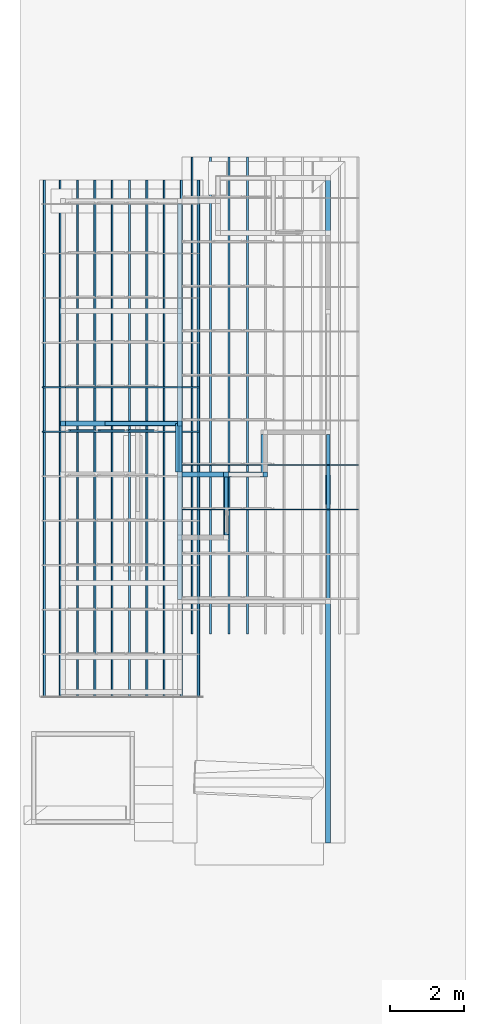
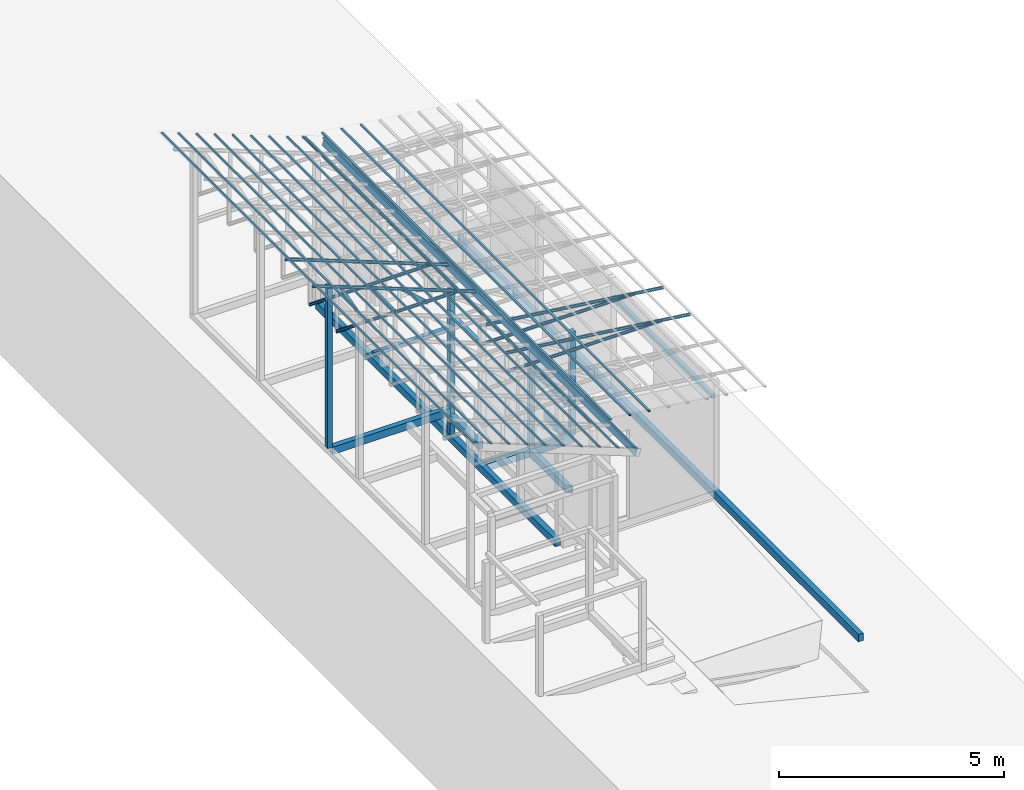
# One storey, part 9 of 22: 26 members, 15 beams, 2 elements without a shape of their own.
"""IFC4 building model written with IfcOpenShell, lengths in millimetres."""

from ifc_helpers import new_model, entity, si_unit, converted_unit, frame, origin_with_axes, origin_2d_with_axis, place, context, subcontext, project, spatial, indexed_curve, rectangle, hollow_rectangle, c_section, outline, extrude, clip, halfspace, material, material_profile, profile_set, profile_usage, type_object, element, aggregate, save


model = new_model("IFC4")

# Units and contexts
model_context = context("Model", 3, precision=1e-05, world=origin_with_axes())
plan_context = context("Plan", 2, precision=1e-05, world=origin_2d_with_axis())
body_context = subcontext(model_context, "Body", "Model", "MODEL_VIEW")
ifc_project = project(units=[si_unit("VOLUMEUNIT", "CUBIC_METRE"), si_unit("LENGTHUNIT", "METRE", prefix="MILLI"), si_unit("AREAUNIT", "SQUARE_METRE"), converted_unit("PLANEANGLEUNIT", "degree", entity("IfcReal", 0.0174532925199433), si_unit("PLANEANGLEUNIT", "RADIAN"), dimensions=[0, 0, 0, 0, 0, 0, 0])], contexts=[model_context, plan_context])

# Site, building, storey
site_placement = place(None, origin_with_axes())
site = spatial("IfcSite", under=ifc_project, at=site_placement)
building_placement = place(site_placement, origin_with_axes())
building = spatial("IfcBuilding", under=site, at=building_placement, Name="2")
storey_placement = place(building_placement, frame((0.0, 0.0, 200.000002980232), z_axis=(0.0, 0.0, 1.0), x_axis=(1.0, 0.0, 0.0)))
storey = spatial("IfcBuildingStorey", under=building, at=storey_placement)

# Beams
ifc_material_1 = material(Name="Concrete")
ifc_material_profile_1 = material_profile(ifc_material_1, outline(indexed_curve([(-65.0, 99.9999923706055), (65.0, 99.9999923706055), (65.0, -99.9999923706055), (-65.0, -99.9999923706055), (-65.0, 99.9999923706055)])))
ifc_profile_set_1 = profile_set([ifc_material_profile_1])
ifc_profile_usage_1 = profile_usage(ifc_profile_set_1, cardinal=2)
beam_type_1 = type_object("IfcBeamType", PredefinedType="BEAM", material=ifc_profile_set_1)
beam_1_placement = place(storey_placement, frame((0.0, 0.0, -200.000002980232), z_axis=(1.50995802528082e-07, 0.99999999999997, 1.94707183709391e-07), x_axis=(-0.999999999999989, 1.50995798738838e-07, 3.24144179769981e-11)))
element("IfcBeam", 1, at=beam_1_placement, inside=storey, type_object=beam_type_1, material=ifc_profile_usage_1, Name="Beam", PredefinedType="BEAM", context=body_context, shape_type="Clipping", body=[
    clip(extrude(outline(indexed_curve([(-65.0, 99.9999923706055), (65.0, 99.9999923706055), (65.0, -99.9999923706055), (-65.0, -99.9999923706055), (-65.0, 99.9999923706055)])), frame((0.0, 100.0, 0.0), z_axis=(0.0, 0.0, 1.0), x_axis=(1.0, 0.0, 0.0)), (0.0, 0.0, 1.0), 17980.0015723856), halfspace(frame((-65.0000050663948, -0.00457252690466703, 17980.001449585), z_axis=(0.707109749317169, -1.79824851898047e-07, 0.707103788852692), x_axis=(-2.54309676923125e-07, -0.999999999999968, 0.0)), False)),
])
ifc_profile_usage_2 = profile_usage(ifc_profile_set_1, cardinal=2)
beam_2_placement = place(storey_placement, frame((-2749.99499320984, 8165.00186920166, -200.000161831838), z_axis=(8.74227978897559e-08, 0.999999999999977, 1.94707183709393e-07), x_axis=(-0.999999999999992, 8.74227765734752e-08, 8.74227836789026e-08)))
element("IfcBeam", 2, at=beam_2_placement, inside=storey, type_object=beam_type_1, material=ifc_profile_usage_2, Name="Beam", PredefinedType="BEAM", context=body_context, shape_type="Clipping", body=[
    clip(extrude(outline(indexed_curve([(-65.0, 99.9999923706055), (65.0, 99.9999923706055), (65.0, -99.9999923706055), (-65.0, -99.9999923706055), (-65.0, 99.9999923706055)])), frame((0.0, 100.0, 0.0), z_axis=(0.0, 0.0, 1.0), x_axis=(1.0, 0.0, 0.0)), (0.0, 0.0, 1.0), 1699.99883876093), halfspace(frame((-65.000057220459, 0.000885935833139229, -0.00118840398499742), z_axis=(0.70710414648056, 9.55323073981162e-08, -0.707109451293945), x_axis=(1.35103588168171e-07, -0.999999999999991, 0.0)), False)),
])
ifc_profile_usage_3 = profile_usage(ifc_profile_set_1, cardinal=2)
beam_3_placement = place(storey_placement, frame((-3934.99755859375, 9930.00030517578, -199.999908873252), z_axis=(0.999999999999825, 5.20548553595199e-07, -2.82129974493678e-07), x_axis=(-5.2054855359522e-07, 0.999999999999865, 5.68434188608003e-14)))
element("IfcBeam", 3, at=beam_3_placement, inside=storey, type_object=beam_type_1, material=ifc_profile_usage_3, Name="Beam", PredefinedType="BEAM", context=body_context, shape_type="Clipping", body=[
    clip(extrude(outline(indexed_curve([(-65.0, 99.9999923706055), (65.0, 99.9999923706055), (65.0, -99.9999923706055), (-65.0, -99.9999923706055), (-65.0, 99.9999923706055)])), frame((0.0, 100.0, 0.0), z_axis=(0.0, 0.0, 1.0), x_axis=(1.0, 0.0, 0.0)), (0.0, 0.0, 1.0), 2254.99774281488), halfspace(frame((-64.9996623396873, 0.000666959067530115, 2254.99749183655), z_axis=(0.707109272480011, 1.46940550393992e-07, 0.707104206085205), x_axis=(2.07804587088261e-07, -0.999999999999978, 0.0)), False)),
])
ifc_profile_usage_4 = profile_usage(ifc_profile_set_1, cardinal=2)
beam_4_placement = place(storey_placement, frame((-1745.00000476837, 9865.0016784668, -200.000298664889), z_axis=(-3.89414367418764e-07, 0.999999999999921, 7.54979012640374e-08), x_axis=(-0.999999999999921, -3.89414367418764e-07, 7.43238217637496e-08)))
element("IfcBeam", 4, at=beam_4_placement, inside=storey, type_object=beam_type_1, material=ifc_profile_usage_4, Name="Beam", PredefinedType="BEAM", context=body_context, shape_type="Clipping", body=[
    clip(extrude(outline(indexed_curve([(-65.0, 99.9999923706055), (65.0, 99.9999923706055), (65.0, -99.9999923706055), (-65.0, -99.9999923706055), (-65.0, 99.9999923706055)])), frame((0.0, 100.0, 0.0), z_axis=(0.0, 0.0, 1.0), x_axis=(1.0, 0.0, 0.0)), (0.0, 0.0, 1.0), 1135.00023417544), halfspace(frame((-65.0000870227814, 0.000425379340640575, -0.000299458179142675), z_axis=(0.70710414648056, 5.33852926309919e-08, -0.707109332084656), x_axis=(7.54984861801534e-08, -0.999999999999997, 0.0)), False)),
])
ifc_profile_usage_5 = profile_usage(ifc_profile_set_1, cardinal=3)
beam_5_placement = place(storey_placement, frame((-3934.99732017517, 6565.00053405762, -200.00042633302), z_axis=(3.89414367418746e-07, 0.999999999999875, 3.13916473260139e-07), x_axis=(-0.999999999999924, 3.89414367418765e-07, -7.40532613008271e-09)))
element("IfcBeam", 5, at=beam_5_placement, inside=storey, type_object=beam_type_1, material=ifc_profile_usage_5, Name="Beam", PredefinedType="BEAM", context=body_context, shape_type="SweptSolid", body=[
    extrude(outline(indexed_curve([(-65.0, 99.9999923706055), (65.0, 99.9999923706055), (65.0, -99.9999923706055), (-65.0, -99.9999923706055), (-65.0, 99.9999923706055)])), frame((65.0000076293945, 100.0, 0.0), z_axis=(0.0, 0.0, 1.0), x_axis=(1.0, 0.0, 0.0)), (0.0, 0.0, 1.0), 10669.999992565),
])
ifc_profile_usage_6 = profile_usage(ifc_profile_set_1, cardinal=2)
beam_6_placement = place(storey_placement, frame((-7084.99765396118, 11300.0049591064, 535.000070929528), z_axis=(0.999999999999932, -1.9470714107682e-07, 3.13916473260157e-07), x_axis=(1.94707183709391e-07, 0.99999999999997, -1.49011611938472e-07)))
element("IfcBeam", 6, at=beam_6_placement, inside=storey, type_object=beam_type_1, material=ifc_profile_usage_6, Name="Beam", PredefinedType="BEAM", context=body_context, shape_type="SweptSolid", body=[
    extrude(outline(indexed_curve([(-65.0, 99.9999923706055), (65.0, 99.9999923706055), (65.0, -99.9999923706055), (-65.0, -99.9999923706055), (-65.0, 99.9999923706055)])), frame((0.0, 100.0, 0.0), z_axis=(0.0, 0.0, 1.0), x_axis=(1.0, 0.0, 0.0)), (0.0, 0.0, 1.0), 3020.00196570558),
])
ifc_profile_usage_7 = profile_usage(ifc_profile_set_1, cardinal=3)
beam_7_placement = place(storey_placement, frame((-3934.99612808228, 9994.99988555908, 355.003580451012), z_axis=(3.89414367418746e-07, 0.999999999999875, 3.13916473260139e-07), x_axis=(-0.999999999999924, 3.89414367418765e-07, -7.40532613008271e-09)))
element("IfcBeam", 7, at=beam_7_placement, inside=storey, type_object=beam_type_1, material=ifc_profile_usage_7, Name="Beam", PredefinedType="BEAM", context=body_context, shape_type="SweptSolid", body=[
    extrude(outline(indexed_curve([(-65.0, 99.9999923706055), (65.0, 99.9999923706055), (65.0, -99.9999923706055), (-65.0, -99.9999923706055), (-65.0, 99.9999923706055)])), frame((65.0000076293945, 100.0, 0.0), z_axis=(0.0, 0.0, 1.0), x_axis=(1.0, 0.0, 0.0)), (0.0, 0.0, 1.0), 1365.22865567095),
])
ifc_material_profile_2 = material_profile(ifc_material_1, rectangle(XDim=130.000015258789, YDim=130.000015258789, kind="CURVE"))
ifc_profile_set_2 = profile_set([ifc_material_profile_2])
ifc_profile_usage_8 = profile_usage(ifc_profile_set_2, cardinal=5)
beam_type_2 = type_object("IfcBeamType", PredefinedType="BEAM", material=ifc_profile_set_2)
beam_8_placement = place(storey_placement, frame((-3999.99690055847, 11305.5725097656, -1.49011609718031e-05), z_axis=(0.0, 0.0, 1.0), x_axis=(1.0, 0.0, 0.0)))
element("IfcBeam", 8, at=beam_8_placement, inside=storey, type_object=beam_type_2, material=ifc_profile_usage_8, Name="Column", PredefinedType="BEAM", context=body_context, shape_type="SweptSolid", body=[
    extrude(rectangle(XDim=130.000015258789, YDim=130.000015258789, kind="CURVE"), origin_with_axes(), (0.0, 0.0, 1.0), 3934.94913943236),
])
ifc_profile_usage_9 = profile_usage(ifc_profile_set_2, cardinal=5)
beam_9_placement = place(storey_placement, frame((-7149.99771118164, 11300.0059127808, 735.000059008599), z_axis=(0.0, 0.0, 1.0), x_axis=(1.0, 0.0, 0.0)))
element("IfcBeam", 9, at=beam_9_placement, inside=storey, type_object=beam_type_2, material=ifc_profile_usage_9, Name="Column", PredefinedType="BEAM", context=body_context, shape_type="SweptSolid", body=[
    extrude(rectangle(XDim=130.000015258789, YDim=130.000015258789, kind="CURVE"), origin_with_axes(), (0.0, 0.0, 1.0), 4411.20902133499),
])
ifc_profile_usage_10 = profile_usage(ifc_profile_set_2, cardinal=5)
beam_10_placement = place(storey_placement, frame((-2749.99475479126, 9929.99935150146, -0.000312924384848756), z_axis=(0.0, 0.0, 1.0), x_axis=(1.0, 0.0, 0.0)))
element("IfcBeam", 10, at=beam_10_placement, inside=storey, type_object=beam_type_2, material=ifc_profile_usage_10, Name="Column", PredefinedType="BEAM", context=body_context, shape_type="SweptSolid", body=[
    extrude(rectangle(XDim=130.000015258789, YDim=130.000015258789, kind="CURVE"), origin_with_axes(), (0.0, 0.0, 1.0), 2811.24256423096),
])
ifc_profile_usage_11 = profile_usage(ifc_profile_set_2, cardinal=5)
beam_11_placement = place(storey_placement, frame((-1695.00029087067, 9930.15480041504, -0.000610947608725709), z_axis=(0.0, 0.0, 1.0), x_axis=(1.0, 0.0, 0.0)))
element("IfcBeam", 11, at=beam_11_placement, inside=storey, type_object=beam_type_2, material=ifc_profile_usage_11, Name="Column", PredefinedType="BEAM", context=body_context, shape_type="SweptSolid", body=[
    extrude(rectangle(XDim=130.000015258789, YDim=130.000015258789, kind="CURVE"), origin_with_axes(), (0.0, 0.0, 1.0), 2811.24349712944),
])

# Assembly, members
assembly_1_placement = place(storey_placement, frame((-1561.45393848419, 6600.0657081604, 3019.63977515697), z_axis=(0.0, 0.0, 1.0), x_axis=(1.0, 0.0, 0.0)))
assembly_1 = element("IfcElementAssembly", 12, at=assembly_1_placement, inside=storey, Name="K1")
ifc_material_2 = material(Name="STEEL")
ifc_material_profile_3 = material_profile(ifc_material_2, c_section(Depth=75.0, Width=35.0, WallThickness=1.0, Girth=1.0, kind="CURVE"))
ifc_profile_set_3 = profile_set([ifc_material_profile_3])
ifc_profile_usage_12 = profile_usage(ifc_profile_set_3, cardinal=9)
member_type_1 = type_object("IfcMemberType", Name="C75", PredefinedType="CHORD", material=ifc_profile_set_3)
member_1_placement = place(assembly_1_placement, frame((2381.98524713516, 2398.93293380737, -28.5120010375977), z_axis=(-0.991864132670109, -9.11591360127481e-08, 0.127300991050989), x_axis=(7.54979012640425e-08, -0.999999999999989, -1.2785038450147e-07)))
member_1 = element("IfcMember", 13, at=member_1_placement, type_object=member_type_1, material=ifc_profile_usage_12, Name="Member", context=body_context, shape_type="SweptSolid", body=[
    extrude(c_section(Depth=75.0, Width=35.0, WallThickness=1.0, Girth=1.0, kind="CURVE"), frame((17.5, -37.5, 0.0), z_axis=(0.0, 0.0, 1.0), x_axis=(1.0, 0.0, 0.0)), (0.0, 0.0, 1.0), 4790.46084290085),
])
ifc_profile_usage_13 = profile_usage(ifc_profile_set_3, cardinal=9)
member_2_placement = place(assembly_1_placement, frame((1634.4433426857, 2398.93293380737, 64.9838447570801), z_axis=(-0.999999999999996, -7.54978941586157e-08, -4.37113882867378e-08), x_axis=(7.54979012640425e-08, -0.999999999999989, -1.2785038450147e-07)))
member_2 = element("IfcMember", 14, at=member_2_placement, type_object=member_type_1, material=ifc_profile_usage_13, Name="Member", context=body_context, shape_type="SweptSolid", body=[
    extrude(c_section(Depth=75.0, Width=35.0, WallThickness=1.0, Girth=1.0, kind="CURVE"), frame((17.5, -37.5, 0.0), z_axis=(0.0, 0.0, 1.0), x_axis=(1.0, 0.0, 0.0)), (0.0, 0.0, 1.0), 4007.95455591631),
])
ifc_profile_usage_14 = profile_usage(ifc_profile_set_3, cardinal=9)
member_3_placement = place(assembly_1_placement, frame((1634.4433426857, 3598.93274307251, 64.9838447570801), z_axis=(-0.999999999999996, -7.54978941586157e-08, -4.37113882867378e-08), x_axis=(7.54979012640425e-08, -0.999999999999989, -1.2785038450147e-07)))
member_3 = element("IfcMember", 15, at=member_3_placement, type_object=member_type_1, material=ifc_profile_usage_14, Name="Member", context=body_context, shape_type="SweptSolid", body=[
    extrude(c_section(Depth=75.0, Width=35.0, WallThickness=1.0, Girth=1.0, kind="CURVE"), frame((17.5, -37.5, 0.0), z_axis=(0.0, 0.0, 1.0), x_axis=(1.0, 0.0, 0.0)), (0.0, 0.0, 1.0), 4007.95455591631),
])
ifc_profile_usage_15 = profile_usage(ifc_profile_set_3, cardinal=9)
member_4_placement = place(assembly_1_placement, frame((2381.98524713516, 3598.93274307251, -28.5120010375977), z_axis=(-0.991864132670109, -9.11591360127481e-08, 0.127300991050989), x_axis=(7.54979012640425e-08, -0.999999999999989, -1.2785038450147e-07)))
member_4 = element("IfcMember", 16, at=member_4_placement, type_object=member_type_1, material=ifc_profile_usage_15, Name="Member", context=body_context, shape_type="SweptSolid", body=[
    extrude(c_section(Depth=75.0, Width=35.0, WallThickness=1.0, Girth=1.0, kind="CURVE"), frame((17.5, -37.5, 0.0), z_axis=(0.0, 0.0, 1.0), x_axis=(1.0, 0.0, 0.0)), (0.0, 0.0, 1.0), 4790.46084290085),
])
aggregate(assembly_1, [member_1, member_2, member_3, member_4])

assembly_2_placement = place(storey_placement, frame((-3938.51041793823, 5099.00283813477, 3935.3459328413), z_axis=(0.0, 0.0, 1.0), x_axis=(1.0, 0.0, 0.0)))
assembly_2 = element("IfcElementAssembly", 17, at=assembly_2_placement, inside=storey, Name="2")
ifc_profile_usage_16 = profile_usage(ifc_profile_set_3, cardinal=1)
member_5_placement = place(assembly_2_placement, frame((3.51285934448242, 5964.99919891357, -1.35517120361328), z_axis=(-0.999999999999812, -4.33125762810878e-07, 4.33125762810878e-07), x_axis=(4.33125762810919e-07, -0.999999999999906, -1.13742348872837e-13)))
member_5 = element("IfcMember", 18, at=member_5_placement, type_object=member_type_1, material=ifc_profile_usage_16, Name="Member", context=body_context, shape_type="SweptSolid", body=[
    extrude(c_section(Depth=75.0, Width=35.0, WallThickness=1.0, Girth=1.0, kind="CURVE"), frame((-17.5, 37.5, 0.0), z_axis=(0.0, 0.0, 1.0), x_axis=(1.0, 0.0, 0.0)), (0.0, 0.0, 1.0), 3150.02386296032),
])
ifc_profile_usage_17 = profile_usage(ifc_profile_set_3, cardinal=3)
member_6_placement = place(assembly_2_placement, frame((-2271.51107788086, 5999.99904632568, 894.618034362793), z_axis=(0.578723368640778, -7.49756619914683e-07, -0.815523919078103), x_axis=(1.02917226740772e-06, 0.999999999999453, -1.89020340712783e-07)))
member_6 = element("IfcMember", 19, at=member_6_placement, type_object=member_type_1, material=ifc_profile_usage_17, Name="Member", context=body_context, shape_type="SweptSolid", body=[
    extrude(c_section(Depth=75.0, Width=35.0, WallThickness=1.0, Girth=1.0, kind="CURVE"), frame((17.5, 37.5, 0.0), z_axis=(0.0, 0.0, 1.0), x_axis=(1.0, 0.0, 0.0)), (0.0, 0.0, 1.0), 1142.30360336039),
])
ifc_profile_usage_18 = profile_usage(ifc_profile_set_3, cardinal=7)
member_7_placement = place(assembly_2_placement, frame((-1445.26290893555, 6035.96019744873, 624.074935913086), z_axis=(0.745142107017777, -0.00102660805644996, -0.66690493057482), x_axis=(0.00137753843534741, 0.999999051193456, -2.17762747561669e-07)))
member_7 = element("IfcMember", 20, at=member_7_placement, type_object=member_type_1, material=ifc_profile_usage_18, Name="Member", context=body_context, shape_type="SweptSolid", body=[
    extrude(c_section(Depth=75.0, Width=35.0, WallThickness=1.0, Girth=1.0, kind="CURVE"), frame((-17.5, -37.5, 0.0), z_axis=(0.0, 0.0, 1.0), x_axis=(1.0, 0.0, 0.0)), (0.0, 0.0, 1.0), 937.808496265298),
])
ifc_profile_usage_19 = profile_usage(ifc_profile_set_3, cardinal=9)
member_8_placement = place(assembly_2_placement, frame((-3006.42156600952, 5999.99809265137, 1241.45650863647), z_axis=(0.468464370953309, -3.43728484817469e-07, -0.88348238983423), x_axis=(6.7154434191237e-07, 0.999999999999774, -3.29761675743537e-08)))
member_8 = element("IfcMember", 21, at=member_8_placement, type_object=member_type_1, material=ifc_profile_usage_19, Name="Member", context=body_context, shape_type="SweptSolid", body=[
    extrude(c_section(Depth=75.0, Width=35.0, WallThickness=1.0, Girth=1.0, kind="CURVE"), frame((17.5, -37.5, 0.0), z_axis=(0.0, 0.0, 1.0), x_axis=(1.0, 0.0, 0.0)), (0.0, 0.0, 1.0), 1399.63894386164),
])
ifc_profile_usage_20 = profile_usage(ifc_profile_set_3, cardinal=1)
member_9_placement = place(assembly_2_placement, frame((438.234329223633, 5965.00015258789, -169.034004211426), z_axis=(-0.933001152035968, -8.32115964913738e-07, 0.359873380925658), x_axis=(9.09962921013707e-07, -0.999999999999585, 4.6906695416718e-08)))
member_9 = element("IfcMember", 22, at=member_9_placement, type_object=member_type_1, material=ifc_profile_usage_20, Name="Member", context=body_context, shape_type="SweptSolid", body=[
    extrude(c_section(Depth=75.0, Width=35.0, WallThickness=1.0, Girth=1.0, kind="CURVE"), frame((-17.5, 37.5, 0.0), z_axis=(0.0, 0.0, 1.0), x_axis=(1.0, 0.0, 0.0)), (0.0, 0.0, 1.0), 4510.0754953159),
])
ifc_profile_usage_21 = profile_usage(ifc_profile_set_3, cardinal=1)
member_10_placement = place(assembly_2_placement, frame((3.51285934448242, 7164.99900817871, -1.35517120361328), z_axis=(-0.999999999999812, -4.33125762810878e-07, 4.33125762810878e-07), x_axis=(4.33125762810919e-07, -0.999999999999906, -1.13742348872837e-13)))
member_10 = element("IfcMember", 23, at=member_10_placement, type_object=member_type_1, material=ifc_profile_usage_21, Name="Member", context=body_context, shape_type="SweptSolid", body=[
    extrude(c_section(Depth=75.0, Width=35.0, WallThickness=1.0, Girth=1.0, kind="CURVE"), frame((-17.5, 37.5, 0.0), z_axis=(0.0, 0.0, 1.0), x_axis=(1.0, 0.0, 0.0)), (0.0, 0.0, 1.0), 3150.02386296032),
])
ifc_profile_usage_22 = profile_usage(ifc_profile_set_3, cardinal=1)
member_11_placement = place(assembly_2_placement, frame((438.234329223633, 7164.99996185303, -169.034004211426), z_axis=(-0.933001152035968, -8.32115964913738e-07, 0.359873380925658), x_axis=(9.09962921013707e-07, -0.999999999999585, 4.6906695416718e-08)))
member_11 = element("IfcMember", 24, at=member_11_placement, type_object=member_type_1, material=ifc_profile_usage_22, Name="Member", context=body_context, shape_type="SweptSolid", body=[
    extrude(c_section(Depth=75.0, Width=35.0, WallThickness=1.0, Girth=1.0, kind="CURVE"), frame((-17.5, 37.5, 0.0), z_axis=(0.0, 0.0, 1.0), x_axis=(1.0, 0.0, 0.0)), (0.0, 0.0, 1.0), 4510.0754953159),
])
aggregate(assembly_2, [member_5, member_6, member_7, member_8, member_9, member_10, member_11])

# Members
ifc_material_profile_4 = material_profile(ifc_material_2, hollow_rectangle(XDim=50.0, YDim=33.0, WallThickness=1.0, InnerFilletRadius=1.0, OuterFilletRadius=0.0, kind="CURVE"))
ifc_profile_set_4 = profile_set([ifc_material_profile_4])
ifc_profile_usage_23 = profile_usage(ifc_profile_set_4, cardinal=3)
member_type_2 = type_object("IfcMemberType", PredefinedType="CHORD", material=ifc_profile_set_4)
member_12_placement = place(storey_placement, frame((-2155.15184402466, 5634.99975204468, 3372.32188880444), z_axis=(5.55417489778164e-09, 0.999999999999999, 4.33570832569785e-08), x_axis=(-0.99189443015292, 0.0, 0.127064705688141)))
element("IfcMember", 25, at=member_12_placement, inside=storey, type_object=member_type_2, material=ifc_profile_usage_23, Name="Member", context=body_context, shape_type="SweptSolid", body=[
    extrude(hollow_rectangle(XDim=50.0, YDim=33.0, WallThickness=1.0, InnerFilletRadius=1.0, OuterFilletRadius=0.0, kind="CURVE"), frame((25.0, 16.5, 0.0), z_axis=(0.0, 0.0, 1.0), x_axis=(1.0, 0.0, 0.0)), (0.0, 0.0, 1.0), 12845.0009370286),
])
ifc_profile_usage_24 = profile_usage(ifc_profile_set_4, cardinal=3)
member_13_placement = place(storey_placement, frame((-2651.09920501709, 5634.99975204468, 3435.85424125195), z_axis=(5.55417489778164e-09, 0.999999999999999, 4.33570832569785e-08), x_axis=(-0.99189443015292, 0.0, 0.127064705688141)))
element("IfcMember", 26, at=member_13_placement, inside=storey, type_object=member_type_2, material=ifc_profile_usage_24, Name="Member", context=body_context, shape_type="SweptSolid", body=[
    extrude(hollow_rectangle(XDim=50.0, YDim=33.0, WallThickness=1.0, InnerFilletRadius=1.0, OuterFilletRadius=0.0, kind="CURVE"), frame((25.0, 16.5, 0.0), z_axis=(0.0, 0.0, 1.0), x_axis=(1.0, 0.0, 0.0)), (0.0, 0.0, 1.0), 12845.0009370286),
])
ifc_profile_usage_25 = profile_usage(ifc_profile_set_4, cardinal=3)
member_14_placement = place(storey_placement, frame((-3147.04632759094, 5634.99975204468, 3499.38659369946), z_axis=(5.55417489778164e-09, 0.999999999999999, 4.33570832569785e-08), x_axis=(-0.99189443015292, 0.0, 0.127064705688141)))
element("IfcMember", 27, at=member_14_placement, inside=storey, type_object=member_type_2, material=ifc_profile_usage_25, Name="Member", context=body_context, shape_type="SweptSolid", body=[
    extrude(hollow_rectangle(XDim=50.0, YDim=33.0, WallThickness=1.0, InnerFilletRadius=1.0, OuterFilletRadius=0.0, kind="CURVE"), frame((25.0, 16.5, 0.0), z_axis=(0.0, 0.0, 1.0), x_axis=(1.0, 0.0, 0.0)), (0.0, 0.0, 1.0), 12845.0009370286),
])
ifc_profile_usage_26 = profile_usage(ifc_profile_set_4, cardinal=3)
member_15_placement = place(storey_placement, frame((-3642.99345016479, 5634.99975204468, 3562.91894614697), z_axis=(5.55417489778164e-09, 0.999999999999999, 4.33570832569785e-08), x_axis=(-0.99189443015292, 0.0, 0.127064705688141)))
element("IfcMember", 28, at=member_15_placement, inside=storey, type_object=member_type_2, material=ifc_profile_usage_26, Name="Member", context=body_context, shape_type="SweptSolid", body=[
    extrude(hollow_rectangle(XDim=50.0, YDim=33.0, WallThickness=1.0, InnerFilletRadius=1.0, OuterFilletRadius=0.0, kind="CURVE"), frame((25.0, 16.5, 0.0), z_axis=(0.0, 0.0, 1.0), x_axis=(1.0, 0.0, 0.0)), (0.0, 0.0, 1.0), 12845.0009370286),
])
ifc_profile_usage_27 = profile_usage(ifc_profile_set_4, cardinal=3)
member_16_placement = place(storey_placement, frame((-3473.28567504883, 3935.00542640686, 3836.28682792187), z_axis=(-6.02437779662066e-08, 0.999999999999996, 7.04360303416249e-08), x_axis=(-0.932953539230607, -8.15613889917279e-08, 0.359996796703911)))
element("IfcMember", 29, at=member_16_placement, inside=storey, type_object=member_type_2, material=ifc_profile_usage_27, Name="Member", context=body_context, shape_type="SweptSolid", body=[
    extrude(hollow_rectangle(XDim=50.0, YDim=33.0, WallThickness=1.0, InnerFilletRadius=1.0, OuterFilletRadius=0.0, kind="CURVE"), frame((25.0, 16.5, 0.0), z_axis=(0.0, 0.0, 1.0), x_axis=(1.0, 0.0, 0.0)), (0.0, 0.0, 1.0), 13930.0024282614),
])
ifc_profile_usage_28 = profile_usage(ifc_profile_set_4, cardinal=3)
member_17_placement = place(storey_placement, frame((-3939.76235389709, 3935.00542640686, 4016.28522574902), z_axis=(-6.74248781251661e-08, 0.999999999999997, 4.07806979296764e-08), x_axis=(-0.932953576983475, -7.75851971190367e-08, 0.359996698865048)))
element("IfcMember", 30, at=member_17_placement, inside=storey, type_object=member_type_2, material=ifc_profile_usage_28, Name="Member", context=body_context, shape_type="SweptSolid", body=[
    extrude(hollow_rectangle(XDim=50.0, YDim=33.0, WallThickness=1.0, InnerFilletRadius=1.0, OuterFilletRadius=0.0, kind="CURVE"), frame((25.0, 16.5, 0.0), z_axis=(0.0, 0.0, 1.0), x_axis=(1.0, 0.0, 0.0)), (0.0, 0.0, 1.0), 13930.0024282614),
])
ifc_profile_usage_29 = profile_usage(ifc_profile_set_4, cardinal=3)
member_18_placement = place(storey_placement, frame((-4406.23903274536, 3935.00518798828, 4196.28362357616), z_axis=(-6.74248781251661e-08, 0.999999999999997, 4.07806979296764e-08), x_axis=(-0.932953576983475, -7.75851971190367e-08, 0.359996698865048)))
element("IfcMember", 31, at=member_18_placement, inside=storey, type_object=member_type_2, material=ifc_profile_usage_29, Name="Member", context=body_context, shape_type="SweptSolid", body=[
    extrude(hollow_rectangle(XDim=50.0, YDim=33.0, WallThickness=1.0, InnerFilletRadius=1.0, OuterFilletRadius=0.0, kind="CURVE"), frame((25.0, 16.5, 0.0), z_axis=(0.0, 0.0, 1.0), x_axis=(1.0, 0.0, 0.0)), (0.0, 0.0, 1.0), 13930.0024282614),
])
ifc_profile_usage_30 = profile_usage(ifc_profile_set_4, cardinal=3)
member_19_placement = place(storey_placement, frame((-4872.71595001221, 3935.00518798828, 4376.28202140331), z_axis=(-6.74248781251661e-08, 0.999999999999997, 4.07806979296764e-08), x_axis=(-0.932953576983475, -7.75851971190367e-08, 0.359996698865048)))
element("IfcMember", 32, at=member_19_placement, inside=storey, type_object=member_type_2, material=ifc_profile_usage_30, Name="Member", context=body_context, shape_type="SweptSolid", body=[
    extrude(hollow_rectangle(XDim=50.0, YDim=33.0, WallThickness=1.0, InnerFilletRadius=1.0, OuterFilletRadius=0.0, kind="CURVE"), frame((25.0, 16.5, 0.0), z_axis=(0.0, 0.0, 1.0), x_axis=(1.0, 0.0, 0.0)), (0.0, 0.0, 1.0), 13930.0024282614),
])
ifc_profile_usage_31 = profile_usage(ifc_profile_set_4, cardinal=3)
member_20_placement = place(storey_placement, frame((-5339.19286727905, 3935.00518798828, 4556.28041923046), z_axis=(-6.74248781251661e-08, 0.999999999999997, 4.07806979296764e-08), x_axis=(-0.932953576983475, -7.75851971190367e-08, 0.359996698865048)))
element("IfcMember", 33, at=member_20_placement, inside=storey, type_object=member_type_2, material=ifc_profile_usage_31, Name="Member", context=body_context, shape_type="SweptSolid", body=[
    extrude(hollow_rectangle(XDim=50.0, YDim=33.0, WallThickness=1.0, InnerFilletRadius=1.0, OuterFilletRadius=0.0, kind="CURVE"), frame((25.0, 16.5, 0.0), z_axis=(0.0, 0.0, 1.0), x_axis=(1.0, 0.0, 0.0)), (0.0, 0.0, 1.0), 13930.0024282614),
])
ifc_profile_usage_32 = profile_usage(ifc_profile_set_4, cardinal=3)
member_21_placement = place(storey_placement, frame((-5805.6697845459, 3935.00518798828, 4736.27881705761), z_axis=(-6.74248781251661e-08, 0.999999999999997, 4.07806979296764e-08), x_axis=(-0.932953576983475, -7.75851971190367e-08, 0.359996698865048)))
element("IfcMember", 34, at=member_21_placement, inside=storey, type_object=member_type_2, material=ifc_profile_usage_32, Name="Member", context=body_context, shape_type="SweptSolid", body=[
    extrude(hollow_rectangle(XDim=50.0, YDim=33.0, WallThickness=1.0, InnerFilletRadius=1.0, OuterFilletRadius=0.0, kind="CURVE"), frame((25.0, 16.5, 0.0), z_axis=(0.0, 0.0, 1.0), x_axis=(1.0, 0.0, 0.0)), (0.0, 0.0, 1.0), 13930.0024282614),
])
ifc_profile_usage_33 = profile_usage(ifc_profile_set_4, cardinal=3)
member_22_placement = place(storey_placement, frame((-6272.14622497559, 3935.00518798828, 4916.27721488476), z_axis=(-6.74248781251661e-08, 0.999999999999997, 4.07806979296764e-08), x_axis=(-0.932953576983475, -7.75851971190367e-08, 0.359996698865048)))
element("IfcMember", 35, at=member_22_placement, inside=storey, type_object=member_type_2, material=ifc_profile_usage_33, Name="Member", context=body_context, shape_type="SweptSolid", body=[
    extrude(hollow_rectangle(XDim=50.0, YDim=33.0, WallThickness=1.0, InnerFilletRadius=1.0, OuterFilletRadius=0.0, kind="CURVE"), frame((25.0, 16.5, 0.0), z_axis=(0.0, 0.0, 1.0), x_axis=(1.0, 0.0, 0.0)), (0.0, 0.0, 1.0), 13930.0002374807),
])
ifc_profile_usage_34 = profile_usage(ifc_profile_set_4, cardinal=3)
member_23_placement = place(storey_placement, frame((-6738.62314224243, 3935.00518798828, 5096.27561271191), z_axis=(-6.74248781251661e-08, 0.999999999999997, 4.07806979296764e-08), x_axis=(-0.932953576983475, -7.75851971190367e-08, 0.359996698865048)))
element("IfcMember", 36, at=member_23_placement, inside=storey, type_object=member_type_2, material=ifc_profile_usage_34, Name="Member", context=body_context, shape_type="SweptSolid", body=[
    extrude(hollow_rectangle(XDim=50.0, YDim=33.0, WallThickness=1.0, InnerFilletRadius=1.0, OuterFilletRadius=0.0, kind="CURVE"), frame((25.0, 16.5, 0.0), z_axis=(0.0, 0.0, 1.0), x_axis=(1.0, 0.0, 0.0)), (0.0, 0.0, 1.0), 13930.0002374807),
])
ifc_profile_usage_35 = profile_usage(ifc_profile_set_4, cardinal=3)
member_24_placement = place(storey_placement, frame((-7205.10005950928, 3935.0049495697, 5276.27401053905), z_axis=(-6.74248781251661e-08, 0.999999999999997, 4.07806979296764e-08), x_axis=(-0.932953576983475, -7.75851971190367e-08, 0.359996698865048)))
element("IfcMember", 37, at=member_24_placement, inside=storey, type_object=member_type_2, material=ifc_profile_usage_35, Name="Member", context=body_context, shape_type="SweptSolid", body=[
    extrude(hollow_rectangle(XDim=50.0, YDim=33.0, WallThickness=1.0, InnerFilletRadius=1.0, OuterFilletRadius=0.0, kind="CURVE"), frame((25.0, 16.5, 0.0), z_axis=(0.0, 0.0, 1.0), x_axis=(1.0, 0.0, 0.0)), (0.0, 0.0, 1.0), 13930.0002374807),
])
ifc_profile_usage_36 = profile_usage(ifc_profile_set_4, cardinal=3)
member_25_placement = place(storey_placement, frame((-7634.54437255859, 3935.00518798828, 5441.34216010571), z_axis=(-6.74248781251661e-08, 0.999999999999997, 4.07806979296764e-08), x_axis=(-0.932953576983475, -7.75851971190367e-08, 0.359996698865048)))
element("IfcMember", 38, at=member_25_placement, inside=storey, type_object=member_type_2, material=ifc_profile_usage_36, Name="Member", context=body_context, shape_type="SweptSolid", body=[
    extrude(hollow_rectangle(XDim=50.0, YDim=33.0, WallThickness=1.0, InnerFilletRadius=1.0, OuterFilletRadius=0.0, kind="CURVE"), frame((25.0, 16.5, 0.0), z_axis=(0.0, 0.0, 1.0), x_axis=(1.0, 0.0, 0.0)), (0.0, 0.0, 1.0), 13930.0002374807),
])

# Beams
ifc_material_profile_5 = material_profile(ifc_material_1, rectangle(XDim=100.0, YDim=100.0))
ifc_profile_set_5 = profile_set([ifc_material_profile_5])
ifc_profile_usage_37 = profile_usage(ifc_profile_set_5, cardinal=2)
beam_type_3 = type_object("IfcBeamType", PredefinedType="BEAM", material=ifc_profile_set_5)
beam_12_placement = place(storey_placement, frame((-6009.99402999878, 11300.0049591064, 2815.00034034252), z_axis=(0.999999999999932, -1.9470714107682e-07, 3.13916473260157e-07), x_axis=(1.94707183709391e-07, 0.99999999999997, -1.49011611938472e-07)))
element("IfcBeam", 39, at=beam_12_placement, inside=storey, type_object=beam_type_3, material=ifc_profile_usage_37, Name="Beam", PredefinedType="BEAM", context=body_context, shape_type="SweptSolid", body=[
    extrude(rectangle(XDim=100.0, YDim=100.0), frame((0.0, 50.0, 0.0), z_axis=(0.0, 0.0, 1.0), x_axis=(1.0, 0.0, 0.0)), (0.0, 0.0, 1.0), 1944.9982906426),
])
ifc_profile_usage_38 = profile_usage(ifc_profile_set_5, cardinal=2)
beam_13_placement = place(storey_placement, frame((0.000991287265605933, 6564.99910354614, 2430.00130355358), z_axis=(1.50995802528082e-07, 0.99999999999997, 1.94707183709391e-07), x_axis=(-0.999999999999989, 1.50995802528085e-07, 3.24144183716509e-11)))
element("IfcBeam", 40, at=beam_13_placement, inside=storey, type_object=beam_type_3, material=ifc_profile_usage_38, Name="Beam", PredefinedType="BEAM", context=body_context, shape_type="SweptSolid", body=[
    extrude(rectangle(XDim=100.0, YDim=100.0), frame((0.0, 50.0, 0.0), z_axis=(0.0, 0.0, 1.0), x_axis=(1.0, 0.0, 0.0)), (0.0, 0.0, 1.0), 4435.00093823495),
])
ifc_profile_usage_39 = profile_usage(ifc_profile_set_5)
beam_14_placement = place(storey_placement, frame((-2749.99499320984, 8295.00102996826, 2179.99987304211), z_axis=(8.74227978897559e-08, 0.999999999999977, 1.94707183709393e-07), x_axis=(-0.999999999999992, 8.74227765734752e-08, 8.74227836789026e-08)))
element("IfcBeam", 41, at=beam_14_placement, inside=storey, type_object=beam_type_3, material=ifc_profile_usage_39, Name="Beam", PredefinedType="BEAM", context=body_context, shape_type="SweptSolid", body=[
    extrude(rectangle(XDim=100.0, YDim=100.0), origin_with_axes(), (0.0, 0.0, 1.0), 1569.99970162751),
])
ifc_profile_usage_40 = profile_usage(ifc_profile_set_5, cardinal=2)
beam_15_placement = place(storey_placement, frame((-4064.99671936035, 11300.0049591064, 3265.00014960766), z_axis=(-2.3841853646898e-07, -0.999999999999922, 3.13916473260154e-07), x_axis=(0.99999999999996, -2.38418579101553e-07, -1.49011597727616e-07)))
element("IfcBeam", 42, at=beam_15_placement, inside=storey, type_object=beam_type_3, material=ifc_profile_usage_40, Name="Beam", PredefinedType="BEAM", context=body_context, shape_type="SweptSolid", body=[
    extrude(rectangle(XDim=100.0, YDim=100.0), frame((0.0, 50.0, 0.0), z_axis=(0.0, 0.0, 1.0), x_axis=(1.0, 0.0, 0.0)), (0.0, 0.0, 1.0), 1305.00506345288),
])

# Member
ifc_material_profile_6 = material_profile(ifc_material_2, rectangle(XDim=8.0, YDim=200.0, kind="CURVE"))
ifc_profile_set_6 = profile_set([ifc_material_profile_6])
ifc_profile_usage_41 = profile_usage(ifc_profile_set_6, cardinal=7)
member_type_3 = type_object("IfcMemberType", PredefinedType="CHORD", material=ifc_profile_set_6)
member_26_placement = place(storey_placement, frame((-3461.43126487732, 3934.99898910522, 3867.0447319746), z_axis=(2.26646370583326e-05, 0.999999999396452, 2.63326892150193e-05), x_axis=(-0.933489030519029, 1.17141317615533e-05, 0.358605953329588)))
element("IfcMember", 43, at=member_26_placement, inside=storey, type_object=member_type_3, material=ifc_profile_usage_41, Name="Member", context=body_context, shape_type="SweptSolid", body=[
    extrude(rectangle(XDim=8.0, YDim=200.0, kind="CURVE"), frame((-4.0, -100.0, 0.0), z_axis=(0.0, 0.0, 1.0), x_axis=(1.0, 0.0, 0.0)), (0.0, 0.0, 1.0), 13930.0079136145),
])

save(model, "model.ifc")
